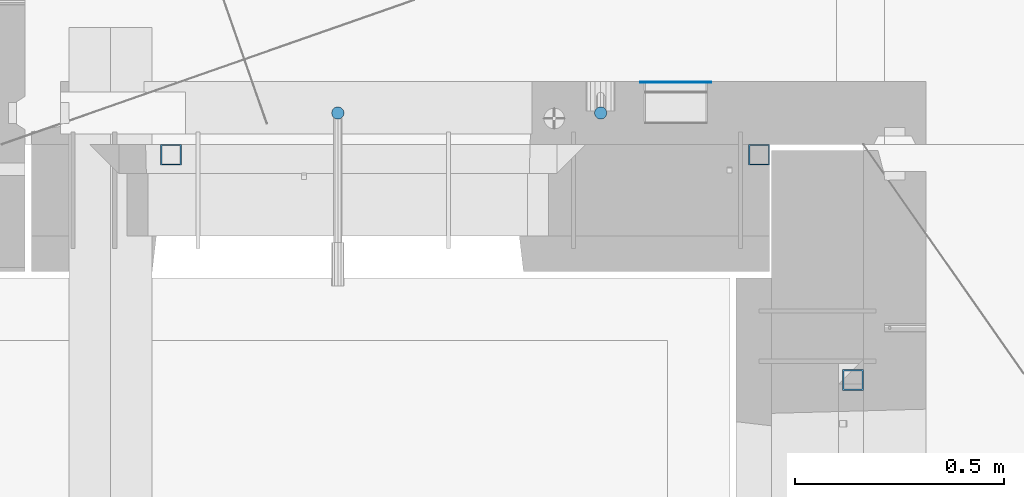
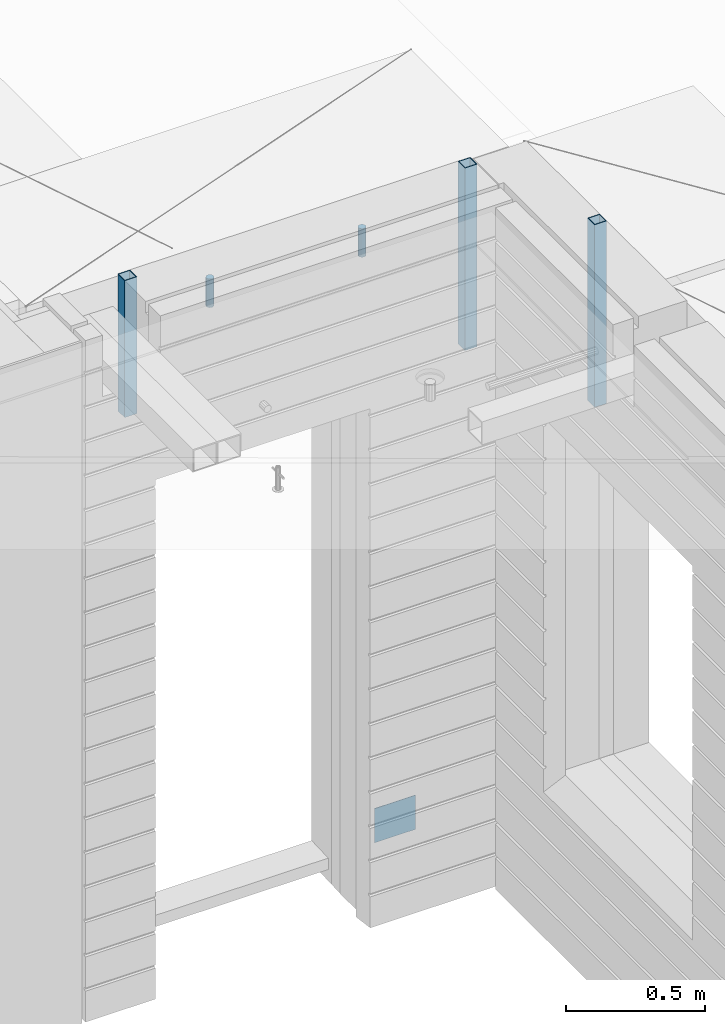
# One storey, part 11 of 309: 6 columns, 6 elements without a shape of their own.
"""IFC2X3 building model written with IfcOpenShell, lengths in millimetres."""

from ifc_helpers import new_model, si_unit, frame, origin_with_axes, place, context, subcontext, project, spatial, faceted_brep, material, type_object, element, aggregate, save


model = new_model("IFC2X3")

# Units and contexts
model_context = context("Model", 3, precision=1e-05, world=origin_with_axes())
body_context = subcontext(model_context, "Body", "Model", "MODEL_VIEW")
ifc_project = project(units=[si_unit("LENGTHUNIT", "METRE", prefix="MILLI"), si_unit("AREAUNIT", "SQUARE_METRE"), si_unit("VOLUMEUNIT", "CUBIC_METRE"), si_unit("MASSUNIT", "GRAM", prefix="KILO"), si_unit("TIMEUNIT", "SECOND"), si_unit("PLANEANGLEUNIT", "RADIAN"), si_unit("SOLIDANGLEUNIT", "STERADIAN"), si_unit("THERMODYNAMICTEMPERATUREUNIT", "DEGREE_CELSIUS"), si_unit("LUMINOUSINTENSITYUNIT", "LUMEN")], contexts=[model_context])

# Site, building, storey
site_placement = place(None, origin_with_axes())
site = spatial("IfcSite", under=ifc_project, at=site_placement, CompositionType="ELEMENT")
building_placement = place(site_placement, origin_with_axes())
building = spatial("IfcBuilding", under=site, at=building_placement, CompositionType="ELEMENT")
storey_placement = place(building_placement, origin_with_axes())
storey = spatial("IfcBuildingStorey", under=building, at=storey_placement, Name="7", CompositionType="ELEMENT", Elevation=0.0)

# Assemblies, columns
assembly_1_placement = place(storey_placement, origin_with_axes())
assembly_1 = element("IfcElementAssembly", 1, at=assembly_1_placement, inside=storey, AssemblyPlace="NOTDEFINED", PredefinedType="REINFORCEMENT_UNIT")
ifc_material_1 = material()
column_type_1 = type_object("IfcColumnType", Name="D30", PredefinedType="NOTDEFINED")
column_1_placement = place(assembly_1_placement, frame((9379.99999999164, 11025.0, 102407.5), z_axis=(0.0, -1.0, 0.0), x_axis=(0.0, 0.0, 1.0)))
column_1 = element("IfcColumn", 2, at=column_1_placement, type_object=column_type_1, material=ifc_material_1, ObjectType="D30", context=body_context, shape_type="Brep", body=[
    faceted_brep([(0.0, -15.0, 0.0), (0.0, -12.9903810567666, -7.5), (125.0, -12.9903810567666, -7.5), (125.0, -15.0, 0.0), (0.0, -7.5, -12.9903810567666), (125.0, -7.5, -12.9903810567666), (0.0, 0.0, -15.0), (125.0, 0.0, -15.0), (0.0, 7.5, -12.9903810567666), (125.0, 7.5, -12.9903810567666), (0.0, 12.9903810567666, -7.5), (125.0, 12.9903810567666, -7.5), (0.0, 15.0, 0.0), (125.0, 15.0, 0.0), (0.0, 12.9903810567666, 7.5), (125.0, 12.9903810567666, 7.5), (0.0, 7.5, 12.9903810567666), (125.0, 7.5, 12.9903810567666), (0.0, 0.0, 15.0), (125.0, 0.0, 15.0), (0.0, -7.5, 12.9903810567666), (125.0, -7.5, 12.9903810567666), (0.0, -12.9903810567666, 7.5), (125.0, -12.9903810567666, 7.5)], [[[0, 1, 2, 3]], [[1, 4, 5, 2]], [[4, 6, 7, 5]], [[6, 8, 9, 7]], [[8, 10, 11, 9]], [[10, 12, 13, 11]], [[12, 14, 15, 13]], [[14, 16, 17, 15]], [[16, 18, 19, 17]], [[18, 20, 21, 19]], [[20, 22, 23, 21]], [[22, 0, 3, 23]], [[5, 7, 9, 11, 13, 15, 17, 19, 21, 23, 3, 2]], [[22, 20, 18, 16, 14, 12, 10, 8, 6, 4, 1, 0]]]),
])
column_2_placement = place(assembly_1_placement, frame((8749.99737962493, 11025.0000022698, 102407.502999914), z_axis=(0.0, 1.0, 0.0), x_axis=(2.90329999844823e-05, 0.0, 0.999999999578542)))
column_2 = element("IfcColumn", 3, at=column_2_placement, type_object=column_type_1, material=ifc_material_1, ObjectType="D30", context=body_context, shape_type="Brep", body=[
    faceted_brep([(0.0, -15.0, 0.0), (0.0, -12.9903810567666, -7.5), (125.0, -12.9903810567666, -7.5), (125.0, -15.0, 0.0), (0.0, -7.5, -12.9903810567666), (125.0, -7.5, -12.9903810567666), (0.0, 0.0, -15.0), (125.0, 0.0, -15.0), (0.0, 7.5, -12.9903810567666), (125.0, 7.5, -12.9903810567666), (0.0, 12.9903810567666, -7.5), (125.0, 12.9903810567666, -7.5), (0.0, 15.0, 0.0), (125.0, 15.0, 0.0), (0.0, 12.9903810567666, 7.5), (125.0, 12.9903810567666, 7.5), (0.0, 7.5, 12.9903810567666), (125.0, 7.5, 12.9903810567666), (0.0, 0.0, 15.0), (125.0, 0.0, 15.0), (0.0, -7.5, 12.9903810567666), (125.0, -7.5, 12.9903810567666), (0.0, -12.9903810567666, 7.5), (125.0, -12.9903810567666, 7.5)], [[[0, 1, 2, 3]], [[1, 4, 5, 2]], [[4, 6, 7, 5]], [[6, 8, 9, 7]], [[8, 10, 11, 9]], [[10, 12, 13, 11]], [[12, 14, 15, 13]], [[14, 16, 17, 15]], [[16, 18, 19, 17]], [[18, 20, 21, 19]], [[20, 22, 23, 21]], [[22, 0, 3, 23]], [[5, 7, 9, 11, 13, 15, 17, 19, 21, 23, 3, 2]], [[22, 20, 18, 16, 14, 12, 10, 8, 6, 4, 1, 0]]]),
])
assembly_2_placement = place(assembly_1_placement, origin_with_axes())
assembly_2 = element("IfcElementAssembly", 4, at=assembly_2_placement, Name="Steel Assembly", AssemblyPlace="NOTDEFINED", PredefinedType="NOTDEFINED")
ifc_material_2 = material(Name="Undefined")
column_type_2 = type_object("IfcColumnType", PredefinedType="NOTDEFINED")
column_3_placement = place(assembly_2_placement, frame((9560.0000000031, 11098.9999999984, 99754.9999999985), z_axis=(0.0, 1.0, 0.0), x_axis=(0.0, 0.0, 1.0)))
column_3 = element("IfcColumn", 5, at=column_3_placement, type_object=column_type_2, material=ifc_material_2, Name="SPK2", context=body_context, shape_type="Brep", body=[
    faceted_brep([(0.0, 85.0, -1.0), (0.0, 85.0, 1.0), (150.0, 85.0, 1.0), (150.0, 85.0, -1.0), (0.0, -85.0, 1.0), (150.0, -85.0, 1.0), (0.0, -85.0, -1.0), (150.0, -85.0, -1.0)], [[[0, 1, 2, 3]], [[1, 4, 5, 2]], [[4, 6, 7, 5]], [[6, 0, 3, 7]], [[5, 7, 3, 2]], [[6, 4, 1, 0]]]),
])
aggregate(assembly_2, [column_3])
assembly_3_placement = place(assembly_1_placement, origin_with_axes())
assembly_3 = element("IfcElementAssembly", 6, at=assembly_3_placement, Name="Steel Assembly", AssemblyPlace="NOTDEFINED", PredefinedType="RIGID_FRAME")
ifc_material_3 = material(Name="STEEL/S355J2")
column_type_3 = type_object("IfcColumnType", Name="50X50X3", PredefinedType="NOTDEFINED")
column_4_placement = place(assembly_3_placement, frame((8350.0, 10925.0, 102140.0), z_axis=(1.0, 0.0, 0.0), x_axis=(0.0, 0.0, 1.0)))
column_4 = element("IfcColumn", 7, at=column_4_placement, type_object=column_type_3, material=ifc_material_3, ObjectType="50X50X3", context=body_context, shape_type="Brep", body=[
    faceted_brep([(0.0, 22.0, -22.0), (0.0, -22.0, -22.0), (600.0, -22.0, -22.0), (600.0, 22.0, -22.0), (0.0, -22.0, 22.0), (600.0, -22.0, 22.0), (0.0, 22.0, 22.0), (600.0, 22.0, 22.0), (0.0, 25.0, -25.0), (0.0, 25.0, 25.0), (600.0, 25.0, 25.0), (600.0, 25.0, -25.0), (0.0, -25.0, 25.0), (600.0, -25.0, 25.0), (0.0, -25.0, -25.0), (600.0, -25.0, -25.0)], [[[0, 1, 2, 3]], [[1, 4, 5, 2]], [[4, 6, 7, 5]], [[6, 0, 3, 7]], [[8, 9, 10, 11]], [[9, 12, 13, 10]], [[12, 14, 15, 13]], [[14, 8, 11, 15]], [[13, 15, 11, 10], [5, 7, 3, 2]], [[14, 12, 9, 8], [6, 4, 1, 0]]]),
])
aggregate(assembly_3, [column_4])
assembly_4_placement = place(assembly_1_placement, origin_with_axes())
assembly_4 = element("IfcElementAssembly", 8, at=assembly_4_placement, Name="Steel Assembly", AssemblyPlace="NOTDEFINED", PredefinedType="RIGID_FRAME")
aggregate(assembly_1, [column_1, column_2, assembly_2, assembly_3, assembly_4])
column_5_placement = place(assembly_4_placement, frame((9760.0, 10925.0, 101940.0), z_axis=(1.0, 0.0, 0.0), x_axis=(0.0, 0.0, 1.0)))
column_5 = element("IfcColumn", 9, at=column_5_placement, type_object=column_type_3, material=ifc_material_3, ObjectType="50X50X3", context=body_context, shape_type="Brep", body=[
    faceted_brep([(0.0, 22.0, -22.0), (0.0, -22.0, -22.0), (800.0, -22.0, -22.0), (800.0, 22.0, -22.0), (0.0, -22.0, 22.0), (800.0, -22.0, 22.0), (0.0, 22.0, 22.0), (800.0, 22.0, 22.0), (0.0, 25.0, -25.0), (0.0, 25.0, 25.0), (800.0, 25.0, 25.0), (800.0, 25.0, -25.0), (0.0, -25.0, 25.0), (800.0, -25.0, 25.0), (0.0, -25.0, -25.0), (800.0, -25.0, -25.0)], [[[0, 1, 2, 3]], [[1, 4, 5, 2]], [[4, 6, 7, 5]], [[6, 0, 3, 7]], [[8, 9, 10, 11]], [[9, 12, 13, 10]], [[12, 14, 15, 13]], [[14, 8, 11, 15]], [[13, 15, 11, 10], [5, 7, 3, 2]], [[14, 12, 9, 8], [6, 4, 1, 0]]]),
])
aggregate(assembly_4, [column_5])

# Assemblies, column
assembly_5_placement = place(storey_placement, origin_with_axes())
assembly_5 = element("IfcElementAssembly", 10, at=assembly_5_placement, inside=storey, AssemblyPlace="NOTDEFINED", PredefinedType="REINFORCEMENT_UNIT")
assembly_6_placement = place(assembly_5_placement, origin_with_axes())
assembly_6 = element("IfcElementAssembly", 11, at=assembly_6_placement, Name="Steel Assembly", AssemblyPlace="NOTDEFINED", PredefinedType="RIGID_FRAME")
aggregate(assembly_5, [assembly_6])
column_6_placement = place(assembly_6_placement, frame((9985.0, 10385.0, 101940.0), z_axis=(0.0, 1.0, 0.0), x_axis=(0.0, 0.0, 1.0)))
column_6 = element("IfcColumn", 12, at=column_6_placement, type_object=column_type_3, material=ifc_material_3, ObjectType="50X50X3", context=body_context, shape_type="Brep", body=[
    faceted_brep([(0.0, 22.0, -22.0), (0.0, -22.0, -22.0), (800.0, -22.0, -22.0), (800.0, 22.0, -22.0), (0.0, -22.0, 22.0), (800.0, -22.0, 22.0), (0.0, 22.0, 22.0), (800.0, 22.0, 22.0), (0.0, 25.0, -25.0), (0.0, 25.0, 25.0), (800.0, 25.0, 25.0), (800.0, 25.0, -25.0), (0.0, -25.0, 25.0), (800.0, -25.0, 25.0), (0.0, -25.0, -25.0), (800.0, -25.0, -25.0)], [[[0, 1, 2, 3]], [[1, 4, 5, 2]], [[4, 6, 7, 5]], [[6, 0, 3, 7]], [[8, 9, 10, 11]], [[9, 12, 13, 10]], [[12, 14, 15, 13]], [[14, 8, 11, 15]], [[13, 15, 11, 10], [5, 7, 3, 2]], [[14, 12, 9, 8], [6, 4, 1, 0]]]),
])
aggregate(assembly_6, [column_6])

save(model, "model.ifc")
